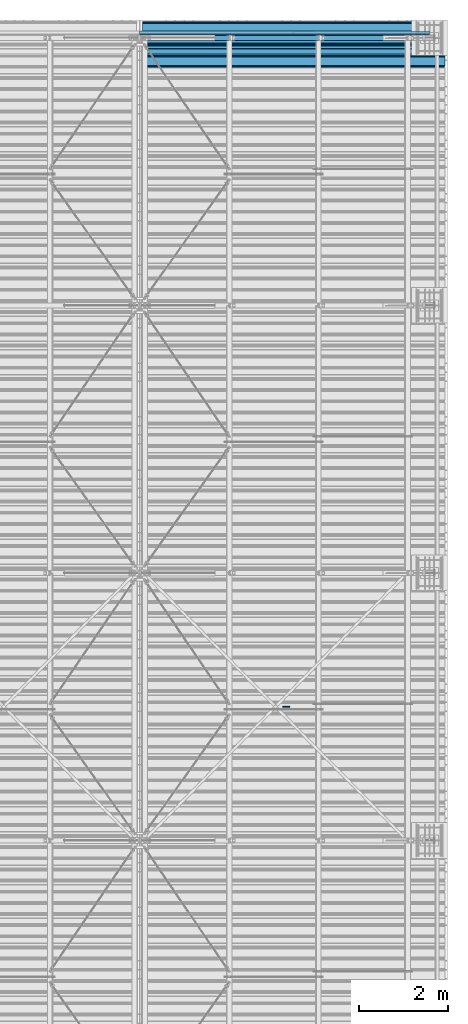
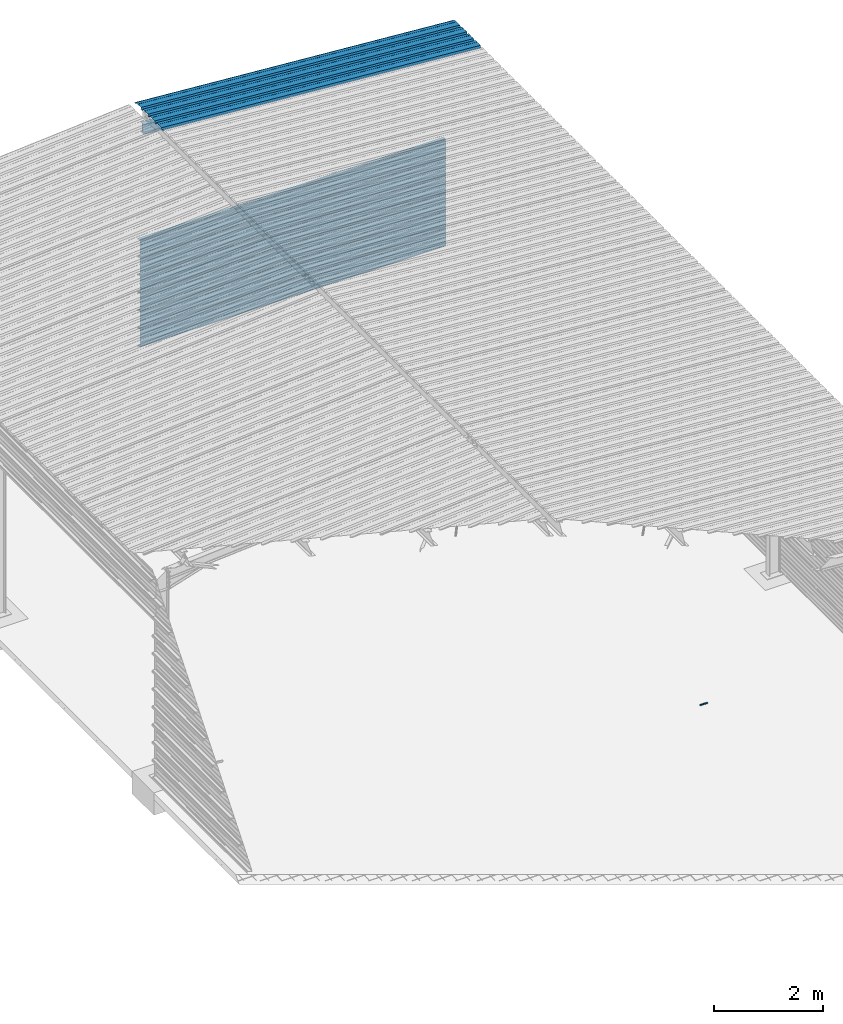
# One storey, part 21 of 70: 9 beams, 9 elements without a shape of their own.
"""IFC2X3 building model written with IfcOpenShell, lengths in millimetres."""

from ifc_helpers import new_model, si_unit, frame, origin_with_axes, origin_2d_with_axis, place, context, subcontext, project, spatial, polyline, i_section, outline, extrude, clip, halfspace, material, type_object, element, aggregate, save


model = new_model("IFC2X3")

# Units and contexts
model_context = context("Model", 3, precision=1e-05, world=origin_with_axes())
body_context = subcontext(model_context, "Body", "Model", "MODEL_VIEW")
ifc_project = project(units=[si_unit("LENGTHUNIT", "METRE", prefix="MILLI"), si_unit("AREAUNIT", "SQUARE_METRE"), si_unit("VOLUMEUNIT", "CUBIC_METRE"), si_unit("MASSUNIT", "GRAM", prefix="KILO"), si_unit("TIMEUNIT", "SECOND"), si_unit("PLANEANGLEUNIT", "RADIAN"), si_unit("SOLIDANGLEUNIT", "STERADIAN"), si_unit("THERMODYNAMICTEMPERATUREUNIT", "DEGREE_CELSIUS"), si_unit("LUMINOUSINTENSITYUNIT", "LUMEN")], contexts=[model_context])

# Site, building, storey
site_placement = place(None, origin_with_axes())
site = spatial("IfcSite", under=ifc_project, at=site_placement, CompositionType="ELEMENT")
building_placement = place(site_placement, origin_with_axes())
building = spatial("IfcBuilding", under=site, at=building_placement, Name="Undefined", CompositionType="ELEMENT")
storey_placement = place(building_placement, origin_with_axes())
storey = spatial("IfcBuildingStorey", under=building, at=storey_placement, Name="Undefined", CompositionType="ELEMENT", Elevation=0.0)

# Assembly, beam
assembly_1_placement = place(storey_placement, origin_with_axes())
assembly_1 = element("IfcElementAssembly", 1, at=assembly_1_placement, inside=storey, Name="Steel Assembly", AssemblyPlace="NOTDEFINED", PredefinedType="RIGID_FRAME")
ifc_material = material(Name="STEEL/S235JR")
beam_type_1 = type_object("IfcBeamType", Name="4.40", PredefinedType="NOTDEFINED")
beam_1_placement = place(assembly_1_placement, frame((6563.6075113196, 23850.0000000002, 5336.31760454294), z_axis=(-0.0766964990376782, 0.0, -0.997054485489817), x_axis=(0.997054485489817, 0.0, -0.0766964990376783)))
beam_1 = element("IfcBeam", 2, at=beam_1_placement, type_object=beam_type_1, material=ifc_material, ObjectType="4.40", context=body_context, shape_type="SweptSolid", body=[
    extrude(outline(polyline([(509.415161132813, 19.5000000011705), (490.584838867188, 19.5000000011705), (468.084838867188, -20.4999999988113), (406.585784912109, -20.4999999988113), (404.585784912109, -18.4999999988122), (345.414215087891, -18.4999999988122), (343.414215087891, -20.4999999988113), (281.915161132813, -20.4999999988113), (259.415161132813, 19.5000000011705), (240.584854125977, 19.5000000011705), (218.084854125977, -20.4999999988113), (156.585784912109, -20.4999999988113), (154.585784912109, -18.4999999988122), (95.4142150878906, -18.4999999988122), (93.4142150878906, -20.4999999988113), (31.9151515960693, -20.4999999988113), (9.41515254974365, 19.5000000011705), (-9.41515254974365, 19.5000000011705), (-31.9151515960693, -20.4999999988113), (-93.4142150878906, -20.4999999988113), (-95.4142150878906, -18.4999999988122), (-154.585784912109, -18.4999999988122), (-156.585784912109, -20.4999999988113), (-218.084854125977, -20.4999999988113), (-240.584854125977, 19.5000000011705), (-259.415161132813, 19.5000000011705), (-281.915161132813, -20.4999999988113), (-343.414215087891, -20.4999999988113), (-345.414215087891, -18.4999999988122), (-404.585784912109, -18.4999999988122), (-406.585784912109, -20.4999999988113), (-468.084838867188, -20.4999999988113), (-490.584838867188, 19.5000000011705), (-509.415161132813, 19.5000000011705), (-516.482360839844, 6.9361057293263), (-517.353942871094, 7.42636680720625), (-510.0, 20.5000000011705), (-490.0, 20.5000000011705), (-467.5, -19.4999999988122), (-407.0, -19.4999999988122), (-405.0, -17.4999999988131), (-345.0, -17.4999999988131), (-343.0, -19.4999999988122), (-282.5, -19.4999999988122), (-260.0, 20.5000000011705), (-240.0, 20.5000000011705), (-217.5, -19.4999999988122), (-157.0, -19.4999999988122), (-155.0, -17.4999999988131), (-95.0, -17.4999999988131), (-93.0, -19.4999999988122), (-32.5, -19.4999999988122), (-10.0, 20.5000000011705), (10.0, 20.5000000011705), (32.5, -19.4999999988122), (93.0, -19.4999999988122), (95.0, -17.4999999988131), (155.0, -17.4999999988131), (157.0, -19.4999999988122), (217.5, -19.4999999988122), (240.0, 20.5000000011705), (260.0, 20.5000000011705), (282.5, -19.4999999988122), (343.0, -19.4999999988122), (345.0, -17.4999999988131), (405.0, -17.4999999988131), (407.0, -19.4999999988122), (467.5, -19.4999999988122), (490.0, 20.5000000011705), (510.0, 20.5000000011705), (517.353942871094, 7.42636680720625), (516.482360839844, 6.9361057293263), (509.415161132813, 19.5000000011705)])), frame((6799.99999999733, 2.8421709430404e-14, 0.0), z_axis=(-1.0, 0.0, 0.0), x_axis=(0.0, -1.0, 0.0)), (0.0, 0.0, 1.0), 6800.0),
])
aggregate(assembly_1, [beam_1])

assembly_2_placement = place(storey_placement, origin_with_axes())
assembly_2 = element("IfcElementAssembly", 3, at=assembly_2_placement, inside=storey, Name="Steel Assembly", AssemblyPlace="NOTDEFINED", PredefinedType="RIGID_FRAME")
beam_type_2 = type_object("IfcBeamType", Name="M14", PredefinedType="NOTDEFINED")
beam_2_placement = place(assembly_2_placement, frame((9864.29374864176, 9000.0, 0.0), z_axis=(0.0, -1.0, 0.0), x_axis=(-1.0, 0.0, 0.0)))
beam_2 = element("IfcBeam", 4, at=beam_2_placement, type_object=beam_type_2, material=ifc_material, ObjectType="M14", context=body_context, shape_type="SweptSolid", body=[
    extrude(outline(polyline([(12.7045926734972, 1.09139364212751e-11), (6.35229633673589, -11.002499999985), (-6.352296336775, -11.0024999999832), (-12.7045926735282, 1.36424205265939e-11), (-6.35229633676863, 11.0025000000087), (6.35229633674408, 11.0025000000069), (12.7045926734972, 1.09139364212751e-11)])), frame((150.0, 0.0, 0.0), z_axis=(-1.0, 0.0, 0.0), x_axis=(0.0, -1.0, 0.0)), (0.0, 0.0, 1.0), 150.0),
])
aggregate(assembly_2, [beam_2])

assembly_3_placement = place(storey_placement, origin_with_axes())
assembly_3 = element("IfcElementAssembly", 5, at=assembly_3_placement, inside=storey, Name="Steel Assembly", AssemblyPlace="NOTDEFINED", PredefinedType="RIGID_FRAME")
beam_type_3 = type_object("IfcBeamType", Name="400", PredefinedType="NOTDEFINED")
beam_3_placement = place(assembly_3_placement, frame((6500.0, 24105.5035213674, 2218.25), z_axis=(0.0, 1.0, 0.0), x_axis=(1.0, 0.0, 0.0)))
beam_3 = element("IfcBeam", 6, at=beam_3_placement, type_object=beam_type_3, material=ifc_material, ObjectType="400", context=body_context, shape_type="SweptSolid", body=[
    extrude(outline(polyline([(218.25, -24.994083404541), (214.25, -31.8999996185303), (214.25, -45.5), (199.75, -45.5), (194.25, -42.5), (188.75, -45.5), (124.25, -45.5), (114.25, -41.5), (104.25, -45.5), (24.25, -45.5), (14.25, -41.5), (4.25, -45.5), (-75.75, -45.5), (-85.75, -41.5), (-95.75, -45.5), (-160.25, -45.5), (-165.75, -42.5), (-171.25, -45.5), (-185.75, -45.5), (-185.75, -30.711540222168), (-181.75, -23.8111782073975), (-181.75, 23.311637878418), (-185.75, 30.2119998931885), (-185.75, 44.5), (-217.25, 44.5), (-217.25, 34.7999992370605), (-218.25, 34.7999992370605), (-218.25, 45.5), (-184.75, 45.5), (-184.75, 30.480884552002), (-180.75, 23.5805225372314), (-180.75, -24.0800628662109), (-184.75, -30.9804248809814), (-184.75, -44.5), (-171.504989624023, -44.5), (-165.75, -41.360912322998), (-159.995010375977, -44.5), (-95.9425811767578, -44.5), (-85.75, -40.422966003418), (-75.5574188232422, -44.5), (4.05741739273071, -44.5), (14.25, -40.422966003418), (24.4425830841064, -44.5), (104.057418823242, -44.5), (114.25, -40.422966003418), (124.442581176758, -44.5), (188.495010375977, -44.5), (194.25, -41.360912322998), (200.004989624023, -44.5), (213.25, -44.5), (213.25, -31.6313018798828), (217.25, -24.7253856658936), (217.25, 21.7253856658936), (213.25, 28.6313018798828), (213.25, 42.0), (187.25, 42.0), (187.25, 32.5499992370605), (186.25, 32.5499992370605), (186.25, 43.0), (214.25, 43.0), (214.25, 28.8999996185303), (218.25, 21.994083404541), (218.25, -24.994083404541)])), frame((6500.0, 0.0, 0.0), z_axis=(-1.0, 0.0, 0.0), x_axis=(0.0, -1.0, 0.0)), (0.0, 0.0, 1.0), 6500.0),
])
aggregate(assembly_3, [beam_3])

assembly_4_placement = place(storey_placement, origin_with_axes())
assembly_4 = element("IfcElementAssembly", 7, at=assembly_4_placement, inside=storey, Name="Steel Assembly", AssemblyPlace="NOTDEFINED", PredefinedType="RIGID_FRAME")
beam_4_placement = place(assembly_4_placement, frame((6500.0, 24105.5035213674, 1818.25), z_axis=(0.0, 1.0, 0.0), x_axis=(1.0, 0.0, 0.0)))
beam_4 = element("IfcBeam", 8, at=beam_4_placement, type_object=beam_type_3, material=ifc_material, ObjectType="400", context=body_context, shape_type="SweptSolid", body=[
    extrude(outline(polyline([(218.25, -24.994083404541), (214.25, -31.8999996185303), (214.25, -45.5), (199.75, -45.5), (194.25, -42.5), (188.75, -45.5), (124.25, -45.5), (114.25, -41.5), (104.25, -45.5), (24.25, -45.5), (14.25, -41.5), (4.25, -45.5), (-75.75, -45.5), (-85.75, -41.5), (-95.75, -45.5), (-160.25, -45.5), (-165.75, -42.5), (-171.25, -45.5), (-185.75, -45.5), (-185.75, -30.711540222168), (-181.75, -23.8111782073975), (-181.75, 23.311637878418), (-185.75, 30.2119998931885), (-185.75, 44.5), (-217.25, 44.5), (-217.25, 34.7999992370605), (-218.25, 34.7999992370605), (-218.25, 45.5), (-184.75, 45.5), (-184.75, 30.480884552002), (-180.75, 23.5805225372314), (-180.75, -24.0800628662109), (-184.75, -30.9804248809814), (-184.75, -44.5), (-171.504989624023, -44.5), (-165.75, -41.360912322998), (-159.995010375977, -44.5), (-95.9425811767578, -44.5), (-85.75, -40.422966003418), (-75.5574188232422, -44.5), (4.05741739273071, -44.5), (14.25, -40.422966003418), (24.4425830841064, -44.5), (104.057418823242, -44.5), (114.25, -40.422966003418), (124.442581176758, -44.5), (188.495010375977, -44.5), (194.25, -41.360912322998), (200.004989624023, -44.5), (213.25, -44.5), (213.25, -31.6313018798828), (217.25, -24.7253856658936), (217.25, 21.7253856658936), (213.25, 28.6313018798828), (213.25, 42.0), (187.25, 42.0), (187.25, 32.5499992370605), (186.25, 32.5499992370605), (186.25, 43.0), (214.25, 43.0), (214.25, 28.8999996185303), (218.25, 21.994083404541), (218.25, -24.994083404541)])), frame((6500.0, 0.0, 0.0), z_axis=(-1.0, 0.0, 0.0), x_axis=(0.0, -1.0, 0.0)), (0.0, 0.0, 1.0), 6500.0),
])
aggregate(assembly_4, [beam_4])

assembly_5_placement = place(storey_placement, origin_with_axes())
assembly_5 = element("IfcElementAssembly", 9, at=assembly_5_placement, inside=storey, Name="Steel Assembly", AssemblyPlace="NOTDEFINED", PredefinedType="RIGID_FRAME")
beam_5_placement = place(assembly_5_placement, frame((6500.0, 24105.5035213674, 1418.25), z_axis=(0.0, 1.0, 0.0), x_axis=(1.0, 0.0, 0.0)))
beam_5 = element("IfcBeam", 10, at=beam_5_placement, type_object=beam_type_3, material=ifc_material, ObjectType="400", context=body_context, shape_type="SweptSolid", body=[
    extrude(outline(polyline([(218.25, -24.994083404541), (214.25, -31.8999996185303), (214.25, -45.5), (199.75, -45.5), (194.25, -42.5), (188.75, -45.5), (124.25, -45.5), (114.25, -41.5), (104.25, -45.5), (24.25, -45.5), (14.25, -41.5), (4.25, -45.5), (-75.75, -45.5), (-85.75, -41.5), (-95.75, -45.5), (-160.25, -45.5), (-165.75, -42.5), (-171.25, -45.5), (-185.75, -45.5), (-185.75, -30.711540222168), (-181.75, -23.8111782073975), (-181.75, 23.311637878418), (-185.75, 30.2119998931885), (-185.75, 44.5), (-217.25, 44.5), (-217.25, 34.7999992370605), (-218.25, 34.7999992370605), (-218.25, 45.5), (-184.75, 45.5), (-184.75, 30.480884552002), (-180.75, 23.5805225372314), (-180.75, -24.0800628662109), (-184.75, -30.9804248809814), (-184.75, -44.5), (-171.504989624023, -44.5), (-165.75, -41.360912322998), (-159.995010375977, -44.5), (-95.9425811767578, -44.5), (-85.75, -40.422966003418), (-75.5574188232422, -44.5), (4.05741739273071, -44.5), (14.25, -40.422966003418), (24.4425830841064, -44.5), (104.057418823242, -44.5), (114.25, -40.422966003418), (124.442581176758, -44.5), (188.495010375977, -44.5), (194.25, -41.360912322998), (200.004989624023, -44.5), (213.25, -44.5), (213.25, -31.6313018798828), (217.25, -24.7253856658936), (217.25, 21.7253856658936), (213.25, 28.6313018798828), (213.25, 42.0), (187.25, 42.0), (187.25, 32.5499992370605), (186.25, 32.5499992370605), (186.25, 43.0), (214.25, 43.0), (214.25, 28.8999996185303), (218.25, 21.994083404541), (218.25, -24.994083404541)])), frame((6500.0, 0.0, 0.0), z_axis=(-1.0, 0.0, 0.0), x_axis=(0.0, -1.0, 0.0)), (0.0, 0.0, 1.0), 6500.0),
])
aggregate(assembly_5, [beam_5])

assembly_6_placement = place(storey_placement, origin_with_axes())
assembly_6 = element("IfcElementAssembly", 11, at=assembly_6_placement, inside=storey, Name="Steel Assembly", AssemblyPlace="NOTDEFINED", PredefinedType="RIGID_FRAME")
beam_6_placement = place(assembly_6_placement, frame((6500.0, 24105.5035213674, 1018.25), z_axis=(0.0, 1.0, 0.0), x_axis=(1.0, 0.0, 0.0)))
beam_6 = element("IfcBeam", 12, at=beam_6_placement, type_object=beam_type_3, material=ifc_material, ObjectType="400", context=body_context, shape_type="SweptSolid", body=[
    extrude(outline(polyline([(218.25, -24.994083404541), (214.25, -31.8999996185303), (214.25, -45.5), (199.75, -45.5), (194.25, -42.5), (188.75, -45.5), (124.25, -45.5), (114.25, -41.5), (104.25, -45.5), (24.25, -45.5), (14.25, -41.5), (4.25, -45.5), (-75.75, -45.5), (-85.75, -41.5), (-95.75, -45.5), (-160.25, -45.5), (-165.75, -42.5), (-171.25, -45.5), (-185.75, -45.5), (-185.75, -30.711540222168), (-181.75, -23.8111782073975), (-181.75, 23.311637878418), (-185.75, 30.2119998931885), (-185.75, 44.5), (-217.25, 44.5), (-217.25, 34.7999992370605), (-218.25, 34.7999992370605), (-218.25, 45.5), (-184.75, 45.5), (-184.75, 30.480884552002), (-180.75, 23.5805225372314), (-180.75, -24.0800628662109), (-184.75, -30.9804248809814), (-184.75, -44.5), (-171.504989624023, -44.5), (-165.75, -41.360912322998), (-159.995010375977, -44.5), (-95.9425811767578, -44.5), (-85.75, -40.422966003418), (-75.5574188232422, -44.5), (4.05741739273071, -44.5), (14.25, -40.422966003418), (24.4425830841064, -44.5), (104.057418823242, -44.5), (114.25, -40.422966003418), (124.442581176758, -44.5), (188.495010375977, -44.5), (194.25, -41.360912322998), (200.004989624023, -44.5), (213.25, -44.5), (213.25, -31.6313018798828), (217.25, -24.7253856658936), (217.25, 21.7253856658936), (213.25, 28.6313018798828), (213.25, 42.0), (187.25, 42.0), (187.25, 32.5499992370605), (186.25, 32.5499992370605), (186.25, 43.0), (214.25, 43.0), (214.25, 28.8999996185303), (218.25, 21.994083404541), (218.25, -24.994083404541)])), frame((6500.0, 0.0, 0.0), z_axis=(-1.0, 0.0, 0.0), x_axis=(0.0, -1.0, 0.0)), (0.0, 0.0, 1.0), 6500.0),
])
aggregate(assembly_6, [beam_6])

assembly_7_placement = place(storey_placement, origin_with_axes())
assembly_7 = element("IfcElementAssembly", 13, at=assembly_7_placement, inside=storey, Name="Steel Assembly", AssemblyPlace="NOTDEFINED", PredefinedType="RIGID_FRAME")
beam_7_placement = place(assembly_7_placement, frame((6500.0, 24105.5035213674, 618.25), z_axis=(0.0, 1.0, 0.0), x_axis=(1.0, 0.0, 0.0)))
beam_7 = element("IfcBeam", 14, at=beam_7_placement, type_object=beam_type_3, material=ifc_material, ObjectType="400", context=body_context, shape_type="SweptSolid", body=[
    extrude(outline(polyline([(218.25, -24.994083404541), (214.25, -31.8999996185303), (214.25, -45.5), (199.75, -45.5), (194.25, -42.5), (188.75, -45.5), (124.25, -45.5), (114.25, -41.5), (104.25, -45.5), (24.25, -45.5), (14.25, -41.5), (4.25, -45.5), (-75.75, -45.5), (-85.75, -41.5), (-95.75, -45.5), (-160.25, -45.5), (-165.75, -42.5), (-171.25, -45.5), (-185.75, -45.5), (-185.75, -30.711540222168), (-181.75, -23.8111782073975), (-181.75, 23.311637878418), (-185.75, 30.2119998931885), (-185.75, 44.5), (-217.25, 44.5), (-217.25, 34.7999992370605), (-218.25, 34.7999992370605), (-218.25, 45.5), (-184.75, 45.5), (-184.75, 30.480884552002), (-180.75, 23.5805225372314), (-180.75, -24.0800628662109), (-184.75, -30.9804248809814), (-184.75, -44.5), (-171.504989624023, -44.5), (-165.75, -41.360912322998), (-159.995010375977, -44.5), (-95.9425811767578, -44.5), (-85.75, -40.422966003418), (-75.5574188232422, -44.5), (4.05741739273071, -44.5), (14.25, -40.422966003418), (24.4425830841064, -44.5), (104.057418823242, -44.5), (114.25, -40.422966003418), (124.442581176758, -44.5), (188.495010375977, -44.5), (194.25, -41.360912322998), (200.004989624023, -44.5), (213.25, -44.5), (213.25, -31.6313018798828), (217.25, -24.7253856658936), (217.25, 21.7253856658936), (213.25, 28.6313018798828), (213.25, 42.0), (187.25, 42.0), (187.25, 32.5499992370605), (186.25, 32.5499992370605), (186.25, 43.0), (214.25, 43.0), (214.25, 28.8999996185303), (218.25, 21.994083404541), (218.25, -24.994083404541)])), frame((6500.0, 0.0, 0.0), z_axis=(-1.0, 0.0, 0.0), x_axis=(0.0, -1.0, 0.0)), (0.0, 0.0, 1.0), 6500.0),
])
aggregate(assembly_7, [beam_7])

assembly_8_placement = place(storey_placement, origin_with_axes())
assembly_8 = element("IfcElementAssembly", 15, at=assembly_8_placement, inside=storey, Name="Steel Assembly", AssemblyPlace="NOTDEFINED", PredefinedType="RIGID_FRAME")
beam_8_placement = place(assembly_8_placement, frame((6500.0, 24105.5035213674, 218.25), z_axis=(0.0, 1.0, 0.0), x_axis=(1.0, 0.0, 0.0)))
beam_8 = element("IfcBeam", 16, at=beam_8_placement, type_object=beam_type_3, material=ifc_material, ObjectType="400", context=body_context, shape_type="SweptSolid", body=[
    extrude(outline(polyline([(218.25, -24.994083404541), (214.25, -31.8999996185303), (214.25, -45.5), (199.75, -45.5), (194.25, -42.5), (188.75, -45.5), (124.25, -45.5), (114.25, -41.5), (104.25, -45.5), (24.25, -45.5), (14.25, -41.5), (4.25, -45.5), (-75.75, -45.5), (-85.75, -41.5), (-95.75, -45.5), (-160.25, -45.5), (-165.75, -42.5), (-171.25, -45.5), (-185.75, -45.5), (-185.75, -30.711540222168), (-181.75, -23.8111782073975), (-181.75, 23.311637878418), (-185.75, 30.2119998931885), (-185.75, 44.5), (-217.25, 44.5), (-217.25, 34.7999992370605), (-218.25, 34.7999992370605), (-218.25, 45.5), (-184.75, 45.5), (-184.75, 30.480884552002), (-180.75, 23.5805225372314), (-180.75, -24.0800628662109), (-184.75, -30.9804248809814), (-184.75, -44.5), (-171.504989624023, -44.5), (-165.75, -41.360912322998), (-159.995010375977, -44.5), (-95.9425811767578, -44.5), (-85.75, -40.422966003418), (-75.5574188232422, -44.5), (4.05741739273071, -44.5), (14.25, -40.422966003418), (24.4425830841064, -44.5), (104.057418823242, -44.5), (114.25, -40.422966003418), (124.442581176758, -44.5), (188.495010375977, -44.5), (194.25, -41.360912322998), (200.004989624023, -44.5), (213.25, -44.5), (213.25, -31.6313018798828), (217.25, -24.7253856658936), (217.25, 21.7253856658936), (213.25, 28.6313018798828), (213.25, 42.0), (187.25, 42.0), (187.25, 32.5499992370605), (186.25, 32.5499992370605), (186.25, 43.0), (214.25, 43.0), (214.25, 28.8999996185303), (218.25, 21.994083404541), (218.25, -24.994083404541)])), frame((6500.0, 0.0, 0.0), z_axis=(-1.0, 0.0, 0.0), x_axis=(0.0, -1.0, 0.0)), (0.0, 0.0, 1.0), 6500.0),
])
aggregate(assembly_8, [beam_8])

assembly_9_placement = place(storey_placement, origin_with_axes())
assembly_9 = element("IfcElementAssembly", 17, at=assembly_9_placement, inside=storey, Name="Steel Assembly", AssemblyPlace="NOTDEFINED", PredefinedType="RIGID_FRAME")
beam_type_4 = type_object("IfcBeamType", Name="IPE220", PredefinedType="NOTDEFINED")
beam_9_placement = place(assembly_9_placement, frame((6491.56338512267, 24000.0, 4990.32400659478), z_axis=(0.0766964990376782, 0.0, 0.997054485489817), x_axis=(0.997054485489817, 0.0, -0.0766964990376783)))
beam_9 = element("IfcBeam", 18, at=beam_9_placement, type_object=beam_type_4, material=ifc_material, Name="POUTRE", ObjectType="IPE220", context=body_context, shape_type="Clipping", body=[
    clip(clip(extrude(i_section(OverallWidth=110.0, OverallDepth=220.0, WebThickness=5.900000095, FlangeThickness=9.199999809, FilletRadius=12.0, at=origin_2d_with_axis()), frame((6409.35743228136, 3.63797880709171e-12, 8.89477024296393e-14), z_axis=(-1.0, 0.0, 0.0), x_axis=(0.0, -1.0, 0.0)), (0.0, 0.0, 1.0), 6402.94), halfspace(frame((6400.72666295692, 3.63797880709171e-12, -109.999999009079), z_axis=(-0.997054485489818, 0.0, -0.0766964990376602), x_axis=(-0.0766964990376602, 0.0, 0.997054485489818)), True)), halfspace(frame((14.9558139963001, 3.63797880709171e-12, 111.150447485664), z_axis=(-0.997054485489818, 0.0, -0.0766964990376602), x_axis=(0.0, -1.0, 0.0)), False)),
])
aggregate(assembly_9, [beam_9])

save(model, "model.ifc")
